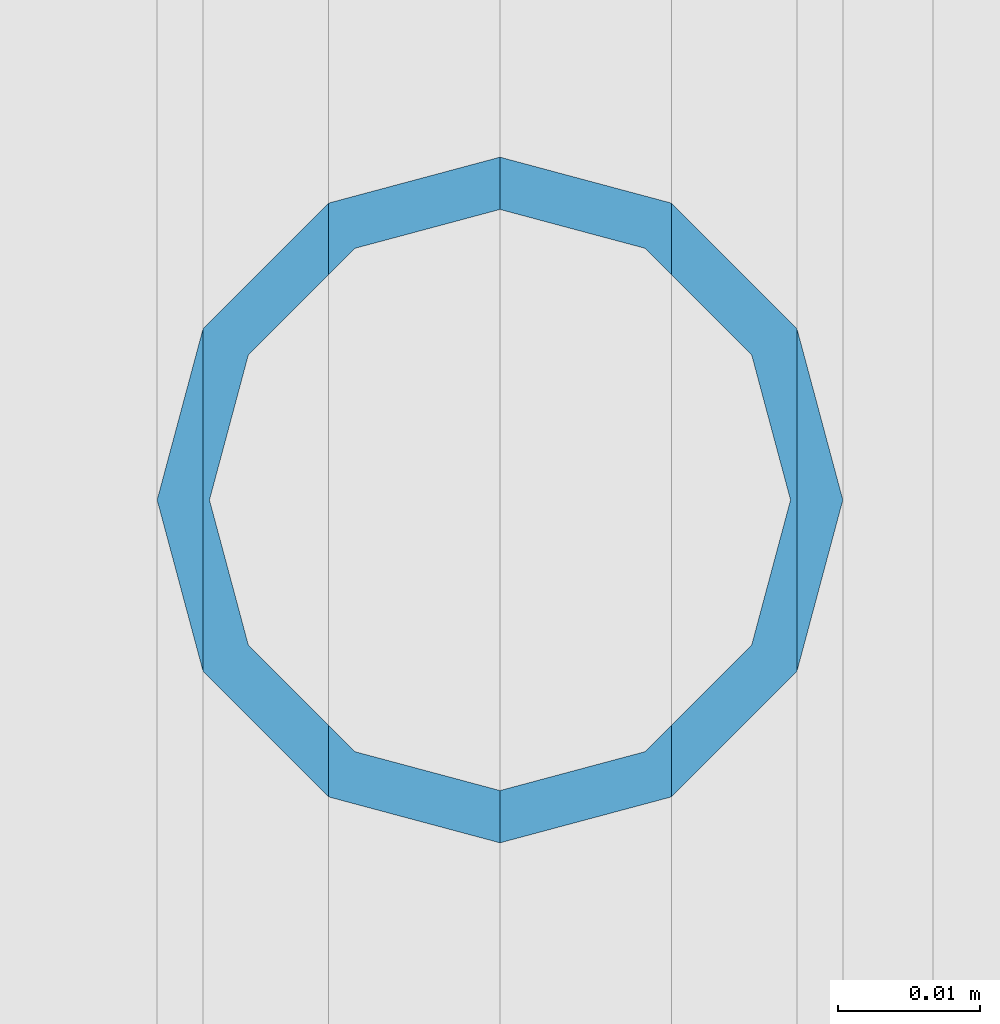
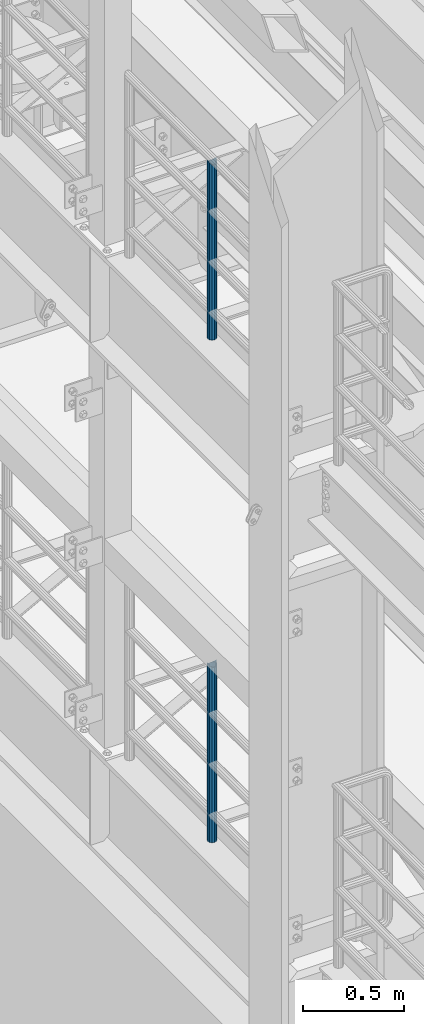
# One storey, part 619 of 1876: 2 columns, 2 elements without a shape of their own.
"""IFC2X3 building model written with IfcOpenShell, lengths in millimetres."""

import ifcopenshell
import ifcopenshell.guid

model = None  # the IFC model being written
_history = None  # IfcOwnerHistory: only IFC2X3 demands one
_inside = {}  # id of a spatial element -> (the spatial element, [elements in it])
_under = {}  # id of a project, library or spatial element -> (it, [spatial elements below it])
_declared = {}  # id of a project -> (the project, [libraries it declares])
_typed = {}  # id of a type object -> (the type object, [elements of that type])
_made_of = {}  # id of a material, layer set ... -> (it, [elements and type objects made of it])


def new_model(schema):
    """Start an empty IFC model of exactly this schema.

    Asked for "IFC4X3", IfcOpenShell would pick the latest addendum, in which some entities
    have other attributes; the version numbers below select the first issue.
    IFC2X3 requires an IfcOwnerHistory on every rooted entity: one is made here for all.
    """
    global model, _history
    if schema == "IFC4X3":
        model = ifcopenshell.file(schema_version=(4, 3, 0, 0))
    else:
        model = ifcopenshell.file(schema=schema)
    _inside.clear()
    _under.clear()
    _declared.clear()
    _typed.clear()
    _made_of.clear()
    _history = None
    if model.schema == "IFC2X3":
        org = make("IfcOrganization", Name="unknown")
        user = make(
            "IfcPersonAndOrganization",
            ThePerson=make("IfcPerson", FamilyName="unknown"),
            TheOrganization=org,
        )
        app = make(
            "IfcApplication",
            ApplicationDeveloper=org,
            Version="unknown",
            ApplicationFullName="unknown",
            ApplicationIdentifier="unknown",
        )
        _history = make(
            "IfcOwnerHistory",
            OwningUser=user,
            OwningApplication=app,
            ChangeAction="ADDED",
            CreationDate=0,
        )
    return model


def make(cls, **values):
    """One entity of the class cls with the attributes given. An attribute that is None is left unset."""
    return model.create_entity(
        cls, **{name: value for name, value in values.items() if value is not None}
    )


def rooted(cls, **values):
    """An entity with a GlobalId (a new one), such as an element, a storey or a relation."""
    return make(cls, GlobalId=ifcopenshell.guid.new(), OwnerHistory=_history, **values)


def si_unit(unit_type, name, prefix=None):
    """IfcSIUnit, for example si_unit("LENGTHUNIT", "METRE", prefix="MILLI")."""
    return make("IfcSIUnit", UnitType=unit_type, Prefix=prefix, Name=name)


def assignment(units):
    """IfcUnitAssignment: the units of a project."""
    return None if units is None else make("IfcUnitAssignment", Units=units)


def point(xyz):
    """IfcCartesianPoint."""
    return None if xyz is None else make("IfcCartesianPoint", Coordinates=xyz)


def direction(xyz):
    """IfcDirection."""
    return None if xyz is None else make("IfcDirection", DirectionRatios=xyz)


def frame(location, z_axis=None, x_axis=None):
    """IfcAxis2Placement3D, a coordinate frame: its origin and axes. An axis left out is left unset."""
    return make(
        "IfcAxis2Placement3D",
        Location=point(location),
        Axis=direction(z_axis),
        RefDirection=direction(x_axis),
    )


def origin_with_axes():
    """The frame at (0, 0, 0) with the z axis (0, 0, 1) and the x axis (1, 0, 0) written out."""
    return frame((0.0, 0.0, 0.0), z_axis=(0.0, 0.0, 1.0), x_axis=(1.0, 0.0, 0.0))


def place(relative_to, where):
    """IfcLocalPlacement: puts the frame where relative to a parent placement (None: the world)."""
    return make(
        "IfcLocalPlacement", PlacementRelTo=relative_to, RelativePlacement=where
    )


def context(
    kind, dimensions, precision=None, world=None, true_north=None, identifier=None
):
    """IfcGeometricRepresentationContext, for example the 3D "Model" context."""
    return make(
        "IfcGeometricRepresentationContext",
        ContextIdentifier=identifier,
        ContextType=kind,
        CoordinateSpaceDimension=dimensions,
        Precision=precision,
        WorldCoordinateSystem=world,
        TrueNorth=true_north,
    )


def subcontext(parent, identifier, kind, view, scale=None):
    """IfcGeometricRepresentationSubContext, for example "Body" below "Model"."""
    return make(
        "IfcGeometricRepresentationSubContext",
        ContextIdentifier=identifier,
        ContextType=kind,
        ParentContext=parent,
        TargetScale=scale,
        TargetView=view,
    )


def project(units=None, contexts=None):
    """IfcProject with its units and contexts."""
    return rooted(
        "IfcProject",
        Name="project",
        RepresentationContexts=contexts,
        UnitsInContext=assignment(units),
    )


def spatial(cls, under=None, at=None, **own):
    """A site, building, storey or space (cls), placed at a placement, below another one or the project."""
    s = rooted(cls, ObjectPlacement=at, **own)
    if under is not None:
        _under.setdefault(under.id(), (under, []))[1].append(s)
    return s


def faces_of(points, faces, orient=None, outer=None):
    """IfcFace entities. A face is a list of loops; a loop is a list of indices into points, from 0.

    orient and outer hold one flag for each loop. By default every Orientation is true, the
    first loop of a face is its IfcFaceOuterBound and the others are IfcFaceBound.
    """
    made = []
    for i, loops in enumerate(faces):
        bounds = []
        for j, loop in enumerate(loops):
            is_outer = j == 0 if outer is None else outer[i][j]
            bounds.append(
                make(
                    "IfcFaceOuterBound" if is_outer else "IfcFaceBound",
                    Bound=make("IfcPolyLoop", Polygon=[points[k] for k in loop]),
                    Orientation=True if orient is None else orient[i][j],
                )
            )
        made.append(make("IfcFace", Bounds=bounds))
    return made


def faceted_brep(points, faces, orient=None, outer=None, voids=None):
    """IfcFacetedBrep: a solid bounded by flat faces; with voids (closed shells), ...WithVoids."""
    shared = [point(p) for p in points]
    hull = make("IfcClosedShell", CfsFaces=faces_of(shared, faces, orient, outer))
    if voids is None:
        return make("IfcFacetedBrep", Outer=hull)
    return make(
        "IfcFacetedBrepWithVoids",
        Outer=hull,
        Voids=[
            make(cls, CfsFaces=faces_of(shared, fs, o, b)) for cls, fs, o, b in voids
        ],
    )


def shape(context_of_items, identifier, shape_type, items):
    """IfcShapeRepresentation: the items that make up one representation, for example the "Body"."""
    return make(
        "IfcShapeRepresentation",
        ContextOfItems=context_of_items,
        RepresentationIdentifier=identifier,
        RepresentationType=shape_type,
        Items=items,
    )


def material(Name=None, Category=None):
    """IfcMaterial."""
    return make("IfcMaterial", Name=Name, Category=Category)


def made_of(thing, what):
    """Note that an element or type object is made of a material, layer set ...; save() writes the relation."""
    if what is not None:
        _made_of.setdefault(what.id(), (what, []))[1].append(thing)
    return thing


def type_object(cls, material=None, **own):
    """A type object (cls), such as IfcWallType, which elements share."""
    return made_of(rooted(cls, **own), material)


def element(
    cls,
    number,
    at=None,
    inside=None,
    cuts=None,
    type_object=None,
    material=None,
    context=None,
    identifier="Body",
    shape_type=None,
    held_by="IfcProductDefinitionShape",
    body=None,
    shapes=None,
    **own,
):
    """One element of the class cls, such as IfcWall. Its Tag is "e" and its number.

    at: its placement. inside: the storey or other place that contains it. cuts: it is an
    opening in that element (IfcRelVoidsElement). A single representation is given by context,
    identifier, shape_type and body (its items); several are given by shapes. held_by: the class
    of the entity that holds the representations. save() writes the other relations.
    """
    e = rooted(cls, Tag="e%d" % number, ObjectPlacement=at, **own)
    if body is not None:
        shapes = [shape(context, identifier, shape_type, body)]
    if shapes is not None:
        e.Representation = make(held_by, Representations=shapes)
    if inside is not None:
        _inside.setdefault(inside.id(), (inside, []))[1].append(e)
    if cuts is not None:
        rooted(
            "IfcRelVoidsElement", RelatingBuildingElement=cuts, RelatedOpeningElement=e
        )
    if type_object is not None:
        _typed.setdefault(type_object.id(), (type_object, []))[1].append(e)
    return made_of(e, material)


def aggregate(whole, parts):
    """IfcRelAggregates: a whole, such as a stair, and the parts it consists of."""
    return rooted("IfcRelAggregates", RelatingObject=whole, RelatedObjects=parts)


def save(model, path):
    """Write the relations noted so far, then the file.

    IfcRelAggregates (storeys below a building ...), IfcRelContainedInSpatialStructure (elements
    in a storey), IfcRelDefinesByType, IfcRelAssociatesMaterial and IfcRelDeclares: one each for
    every whole, place, type object, material and project.
    """
    for whole, parts in _under.values():
        aggregate(whole, parts)
    for where, things in _inside.values():
        rooted(
            "IfcRelContainedInSpatialStructure",
            RelatedElements=things,
            RelatingStructure=where,
        )
    for kind, things in _typed.values():
        rooted("IfcRelDefinesByType", RelatedObjects=things, RelatingType=kind)
    for what, things in _made_of.values():
        rooted("IfcRelAssociatesMaterial", RelatedObjects=things, RelatingMaterial=what)
    for by, libraries in _declared.values():
        rooted("IfcRelDeclares", RelatingContext=by, RelatedDefinitions=libraries)
    model.write(path)


model = new_model("IFC2X3")

# Units and contexts
model_context = context("Model", 3, precision=1e-05, world=origin_with_axes())
body_context = subcontext(model_context, "Body", "Model", "MODEL_VIEW")
ifc_project = project(units=[si_unit("LENGTHUNIT", "METRE", prefix="MILLI"), si_unit("AREAUNIT", "SQUARE_METRE"), si_unit("VOLUMEUNIT", "CUBIC_METRE"), si_unit("MASSUNIT", "GRAM", prefix="KILO"), si_unit("TIMEUNIT", "SECOND"), si_unit("PLANEANGLEUNIT", "RADIAN"), si_unit("SOLIDANGLEUNIT", "STERADIAN"), si_unit("THERMODYNAMICTEMPERATUREUNIT", "DEGREE_CELSIUS"), si_unit("LUMINOUSINTENSITYUNIT", "LUMEN")], contexts=[model_context])

# Site, building, storey
site_placement = place(None, origin_with_axes())
site = spatial("IfcSite", under=ifc_project, at=site_placement, CompositionType="ELEMENT")
building_placement = place(site_placement, origin_with_axes())
building = spatial("IfcBuilding", under=site, at=building_placement, Name="Undefined", CompositionType="ELEMENT")
storey_placement = place(building_placement, origin_with_axes())
storey = spatial("IfcBuildingStorey", under=building, at=storey_placement, Name="Undefined", CompositionType="ELEMENT", Elevation=0.0)

# Assembly, column
assembly_1_placement = place(storey_placement, origin_with_axes())
assembly_1 = element("IfcElementAssembly", 1, at=assembly_1_placement, inside=storey, Name="RAIL", AssemblyPlace="NOTDEFINED", PredefinedType="RIGID_FRAME")
ifc_material = material()
column_type = type_object("IfcColumnType", Name="PIPE1-1/2SCH40", PredefinedType="NOTDEFINED")
column_1_placement = place(assembly_1_placement, frame((-1.81898940354586e-12, -3542.7031, 8153.4), z_axis=(0.0, 1.0, 0.0), x_axis=(0.0, 0.0, 1.0)))
column_1 = element("IfcColumn", 2, at=column_1_placement, type_object=column_type, material=ifc_material, Name="POST", ObjectType="PIPE1-1/2SCH40", context=body_context, shape_type="Brep", body=[
    faceted_brep([(1055.42780700668, -12.0650000000001, 20.8971929933186), (1055.42780700668, -12.0650000000001, 15.8661214311805), (1054.93437856882, -10.2235000000001, 17.7076214311801), (1052.195, 0.0, 20.4470000000001), (1052.195, 0.0, 24.1300000000001), (1054.93437856882, 10.2235000000001, 17.7076214311801), (1055.42780700668, 12.0650000000001, 15.8661214311805), (1055.42780700668, 12.0650000000001, 20.8971929933186), (1076.325, 24.1300000000001, 0.0), (1064.26, 20.8971929933184, 12.0649999999996), (1064.25999999999, 20.8971929933186, -12.0649999999996), (1061.07042843786, 17.7076214311803, 10.2235000000001), (1063.80980700668, 20.4469999999999, 0.0), (1061.07042843786, 17.7076214311803, -10.2235000000001), (1055.42780700668, 12.0650000000001, -15.8661214311805), (1055.42780700667, 12.0649999999996, -20.8971929933186), (1054.93437856882, 10.2235000000001, -17.7076214311801), (1052.195, 0.0, -20.4470000000001), (1052.19499999999, 0.0, -24.1300000000001), (1055.42780700668, -12.0650000000001, -15.8661214311805), (1055.42780700667, -12.0649999999996, -20.8971929933186), (1054.93437856882, -10.2235000000001, -17.7076214311801), (1076.325, -24.1300000000001, 0.0), (1064.25999999999, -20.8971929933186, -12.0649999999996), (1064.26, -20.8971929933184, 12.0649999999996), (1061.07042843786, -17.7076214311803, -10.2235000000001), (1063.80980700668, -20.4469999999999, 0.0), (1061.07042843786, -17.7076214311803, 10.2235000000001), (0.0, -20.8971929933184, -12.0649999999996), (0.0, -12.0650000000001, -20.8971929933186), (-1.45519152283669e-11, 0.0, -24.130000000001), (0.0, 12.0650000000001, -20.8971929933186), (0.0, 20.8971929933184, -12.0649999999996), (0.0, 24.1299999999992, 0.0), (0.0, 20.8971929933184, 12.0649999999996), (0.0, 12.0650000000001, 20.8971929933186), (-1.45519152283669e-11, 0.0, 24.130000000001), (0.0, -12.0650000000001, 20.8971929933186), (0.0, -20.8971929933184, 12.0649999999996), (0.0, -24.1299999999992, 0.0), (0.0, -17.7076214311803, -10.2235000000001), (0.0, -10.2235000000001, -17.7076214311801), (-1.45519152283669e-11, 0.0, -20.4470000000001), (0.0, 10.2235000000001, -17.7076214311801), (0.0, 17.7076214311803, -10.2235000000001), (0.0, 20.4469999999999, 0.0), (0.0, 17.7076214311803, 10.2235000000001), (0.0, 10.2235000000001, 17.7076214311801), (-1.45519152283669e-11, 0.0, 20.4470000000001), (0.0, -10.2235000000001, 17.7076214311801), (0.0, -17.7076214311803, 10.2235000000001), (0.0, -20.4469999999999, 0.0)], [[[0, 1, 2, 3, 4]], [[4, 3, 5, 6, 7]], [[8, 9, 10]], [[7, 6, 11, 12, 13, 14, 15, 10, 9]], [[16, 17, 18, 15, 14]], [[19, 20, 18, 17, 21]], [[22, 23, 24]], [[24, 23, 20, 19, 25, 26, 27, 1, 0]], [[28, 29, 20, 23]], [[29, 30, 18, 20]], [[30, 31, 15, 18]], [[31, 32, 10, 15]], [[32, 33, 8, 10]], [[33, 34, 9, 8]], [[34, 35, 7, 9]], [[35, 36, 4, 7]], [[36, 37, 0, 4]], [[37, 38, 24, 0]], [[38, 39, 22, 24]], [[39, 28, 23, 22]], [[38, 37, 36, 35, 34, 33, 32, 31, 30, 29, 28, 39], [40, 41, 42, 43, 44, 45, 46, 47, 48, 49, 50, 51]], [[40, 51, 26, 25]], [[21, 41, 40, 25, 19]], [[42, 41, 21, 17]], [[43, 42, 17, 16]], [[44, 43, 16, 14, 13]], [[45, 44, 13, 12]], [[46, 45, 12, 11]], [[5, 47, 46, 11, 6]], [[48, 47, 5, 3]], [[49, 48, 3, 2]], [[50, 49, 2, 1, 27]], [[51, 50, 27, 26]]]),
])
aggregate(assembly_1, [column_1])

assembly_2_placement = place(storey_placement, origin_with_axes())
assembly_2 = element("IfcElementAssembly", 3, at=assembly_2_placement, inside=storey, Name="RAIL", AssemblyPlace="NOTDEFINED", PredefinedType="RIGID_FRAME")
column_2_placement = place(assembly_2_placement, frame((-1.81898940354586e-12, -3542.7031, 5130.8), z_axis=(0.0, 1.0, 0.0), x_axis=(0.0, 0.0, 1.0)))
column_2 = element("IfcColumn", 4, at=column_2_placement, type_object=column_type, material=ifc_material, Name="POST", ObjectType="PIPE1-1/2SCH40", context=body_context, shape_type="Brep", body=[
    faceted_brep([(1055.42780700668, -12.0650000000001, 20.8971929933186), (1055.42780700668, -12.0650000000001, 15.8661214311805), (1054.93437856882, -10.2235000000001, 17.7076214311801), (1052.195, 0.0, 20.4470000000001), (1052.195, 0.0, 24.1300000000001), (1054.93437856882, 10.2235000000001, 17.7076214311801), (1055.42780700668, 12.0650000000001, 15.8661214311805), (1055.42780700668, 12.0650000000001, 20.8971929933186), (1076.325, 24.1300000000001, 0.0), (1064.26, 20.8971929933184, 12.0649999999996), (1064.25999999999, 20.8971929933186, -12.0649999999996), (1061.07042843786, 17.7076214311803, 10.2235000000001), (1063.80980700668, 20.4469999999999, 0.0), (1061.07042843786, 17.7076214311803, -10.2235000000001), (1055.42780700668, 12.0650000000001, -15.8661214311805), (1055.42780700667, 12.0649999999996, -20.8971929933186), (1054.93437856882, 10.2235000000001, -17.7076214311801), (1052.195, 0.0, -20.4470000000001), (1052.19499999999, 0.0, -24.1300000000001), (1055.42780700668, -12.0650000000001, -15.8661214311805), (1055.42780700667, -12.0649999999996, -20.8971929933186), (1054.93437856882, -10.2235000000001, -17.7076214311801), (1076.325, -24.1300000000001, 0.0), (1064.25999999999, -20.8971929933186, -12.0649999999996), (1064.26, -20.8971929933184, 12.0649999999996), (1061.07042843786, -17.7076214311803, -10.2235000000001), (1063.80980700668, -20.4469999999999, 0.0), (1061.07042843786, -17.7076214311803, 10.2235000000001), (0.0, -20.8971929933184, -12.0649999999996), (0.0, -12.0650000000001, -20.8971929933186), (-1.45519152283669e-11, 0.0, -24.130000000001), (0.0, 12.0650000000001, -20.8971929933186), (0.0, 20.8971929933184, -12.0649999999996), (0.0, 24.1299999999992, 0.0), (0.0, 20.8971929933184, 12.0649999999996), (0.0, 12.0650000000001, 20.8971929933186), (-1.45519152283669e-11, 0.0, 24.130000000001), (0.0, -12.0650000000001, 20.8971929933186), (0.0, -20.8971929933184, 12.0649999999996), (0.0, -24.1299999999992, 0.0), (0.0, -17.7076214311803, -10.2235000000001), (0.0, -10.2235000000001, -17.7076214311801), (-1.45519152283669e-11, 0.0, -20.4470000000001), (0.0, 10.2235000000001, -17.7076214311801), (0.0, 17.7076214311803, -10.2235000000001), (0.0, 20.4469999999999, 0.0), (0.0, 17.7076214311803, 10.2235000000001), (0.0, 10.2235000000001, 17.7076214311801), (-1.45519152283669e-11, 0.0, 20.4470000000001), (0.0, -10.2235000000001, 17.7076214311801), (0.0, -17.7076214311803, 10.2235000000001), (0.0, -20.4469999999999, 0.0)], [[[0, 1, 2, 3, 4]], [[4, 3, 5, 6, 7]], [[8, 9, 10]], [[7, 6, 11, 12, 13, 14, 15, 10, 9]], [[16, 17, 18, 15, 14]], [[19, 20, 18, 17, 21]], [[22, 23, 24]], [[24, 23, 20, 19, 25, 26, 27, 1, 0]], [[28, 29, 20, 23]], [[29, 30, 18, 20]], [[30, 31, 15, 18]], [[31, 32, 10, 15]], [[32, 33, 8, 10]], [[33, 34, 9, 8]], [[34, 35, 7, 9]], [[35, 36, 4, 7]], [[36, 37, 0, 4]], [[37, 38, 24, 0]], [[38, 39, 22, 24]], [[39, 28, 23, 22]], [[38, 37, 36, 35, 34, 33, 32, 31, 30, 29, 28, 39], [40, 41, 42, 43, 44, 45, 46, 47, 48, 49, 50, 51]], [[40, 51, 26, 25]], [[21, 41, 40, 25, 19]], [[42, 41, 21, 17]], [[43, 42, 17, 16]], [[44, 43, 16, 14, 13]], [[45, 44, 13, 12]], [[46, 45, 12, 11]], [[5, 47, 46, 11, 6]], [[48, 47, 5, 3]], [[49, 48, 3, 2]], [[50, 49, 2, 1, 27]], [[51, 50, 27, 26]]]),
])
aggregate(assembly_2, [column_2])

save(model, "model.ifc")
